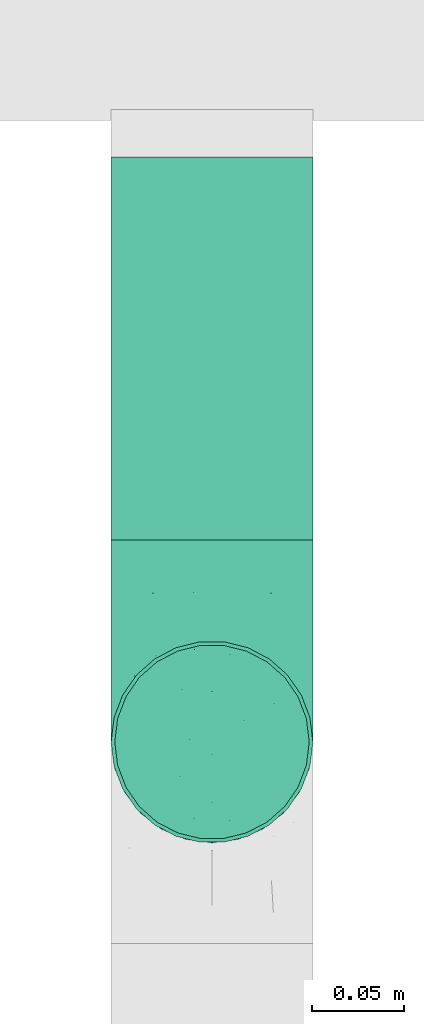
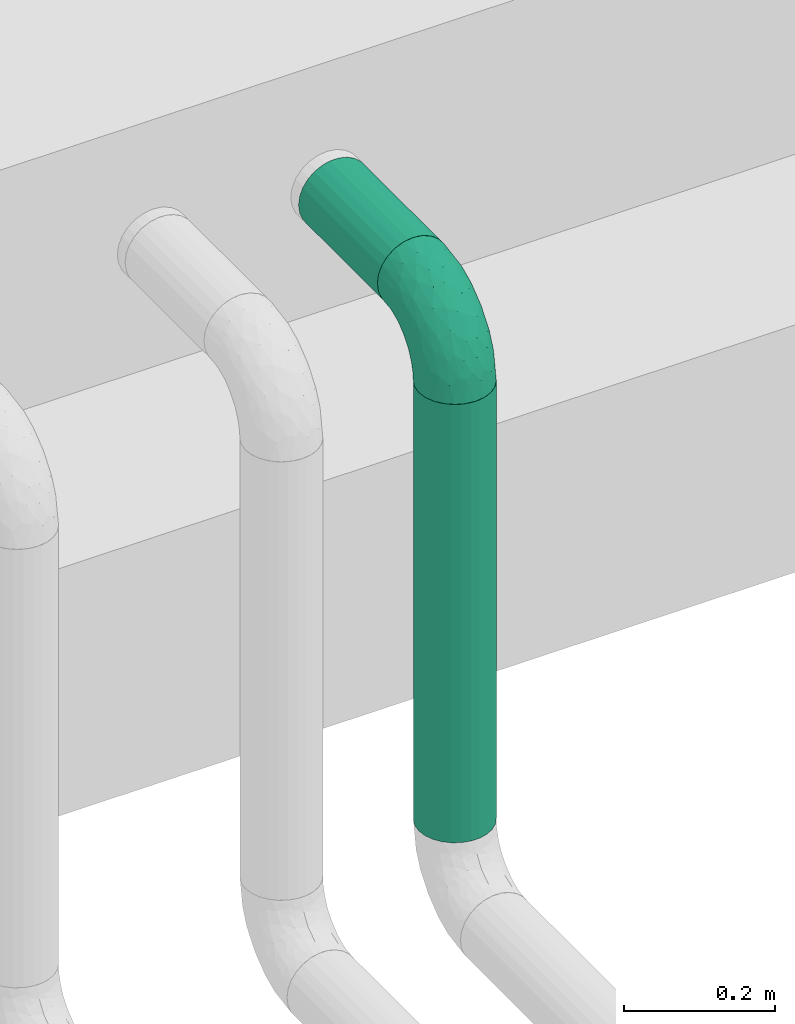
# One storey, part 25 of 91: 2 flow segments, 1 flow fitting.
"""IFC2X3 building model written with IfcOpenShell, lengths in millimetres."""

from ifc_helpers import new_model, entity, si_unit, converted_unit, derived_unit, direction, frame, origin_with_axes, origin_2d_with_axis, place, context, subcontext, project, spatial, hollow_circle, extrude, open_shell, surface_model, source, transform, mapped, material, layer, layer_set, layer_usage, type_object, element, save


model = new_model("IFC2X3")

# Units and contexts
model_context = context("Model", 3, precision=1e-05, world=origin_with_axes(), true_north=direction((0.0, 1.0)))
body_context = subcontext(model_context, "Body", "Model", "MODEL_VIEW")
ifc_project = project(units=[si_unit("AREAUNIT", "SQUARE_METRE"), si_unit("VOLUMEUNIT", "CUBIC_METRE", prefix="DECI"), si_unit("TIMEUNIT", "SECOND"), si_unit("THERMODYNAMICTEMPERATUREUNIT", "DEGREE_CELSIUS"), si_unit("PRESSUREUNIT", "PASCAL"), si_unit("MASSUNIT", "GRAM", prefix="KILO"), si_unit("LENGTHUNIT", "METRE", prefix="MILLI"), si_unit("POWERUNIT", "WATT"), si_unit("ELECTRICCURRENTUNIT", "AMPERE"), si_unit("ELECTRICVOLTAGEUNIT", "VOLT"), derived_unit("VOLUMETRICFLOWRATEUNIT", [(si_unit("VOLUMEUNIT", "CUBIC_METRE", prefix="DECI"), 1), (si_unit("TIMEUNIT", "SECOND"), -1)]), derived_unit("LINEARVELOCITYUNIT", [(si_unit("LENGTHUNIT", "METRE"), 1), (si_unit("TIMEUNIT", "SECOND"), -1)]), derived_unit("MASSDENSITYUNIT", [(si_unit("MASSUNIT", "GRAM", prefix="KILO"), 1), (si_unit("VOLUMEUNIT", "CUBIC_METRE"), -1)]), converted_unit("PLANEANGLEUNIT", "DEGREE", entity("IfcRatioMeasure", 0.01745), si_unit("PLANEANGLEUNIT", "RADIAN"), dimensions=[0, 0, 0, 0, 0, 0, 0])], contexts=[model_context])

# Site, building, storey
site_placement = place(None, origin_with_axes())
site = spatial("IfcSite", under=ifc_project, at=site_placement, CompositionType="ELEMENT")
building_placement = place(site_placement, origin_with_axes())
building = spatial("IfcBuilding", under=site, at=building_placement, Name="mc-building", CompositionType="ELEMENT")
storey_placement = place(building_placement, frame((0.0, 0.0, 8700.0), z_axis=(0.0, 0.0, 1.0), x_axis=(1.0, 0.0, 0.0)))
storey = spatial("IfcBuildingStorey", under=building, at=storey_placement, CompositionType="ELEMENT", Elevation=8700.0)

# Flow segments
ifc_material = material(Name="FZ1")
ifc_layer = layer(ifc_material, 0.0)
ifc_layer_set = layer_set([ifc_layer], Name="FZ1")
ifc_layer_usage = layer_usage(ifc_layer_set, "AXIS1", "POSITIVE", 0.0)
duct_segment_type = type_object("IfcDuctSegmentType", PredefinedType="RIGIDSEGMENT")
shared_shape_1 = source(origin_with_axes(), body_context, "Body", "SweptSolid", [
    extrude(hollow_circle(Radius=55.0, WallThickness=2.0, at=origin_2d_with_axis()), frame((0.0, 0.0, 0.0), z_axis=(1.0, 0.0, 0.0), x_axis=(0.0, 1.0, 0.0)), (0.0, 0.0, 1.0), 709.0),
])
flow_segment_1_placement = place(storey_placement, frame((16466.11947, 2612.35324, 1234.0), z_axis=(0.0, 1.0, 0.0), x_axis=(0.0, 0.0, -1.0)))
element("IfcFlowSegment", 1, at=flow_segment_1_placement, inside=storey, type_object=duct_segment_type, material=ifc_layer_usage, context=body_context, shape_type="MappedRepresentation", body=[
    mapped(shared_shape_1, transform((0.0, 0.0, 0.0), scale=1.0)),
])
shared_shape_2 = source(origin_with_axes(), body_context, "Body", "SweptSolid", [
    extrude(hollow_circle(Radius=55.0, WallThickness=2.0, at=origin_2d_with_axis()), frame((0.0, 0.0, 0.0), z_axis=(1.0, 0.0, 0.0), x_axis=(0.0, 1.0, 0.0)), (0.0, 0.0, 1.0), 208.9),
])
flow_segment_2_placement = place(storey_placement, frame((16466.11947, 2931.20513, 1344.0), z_axis=(0.0, 0.0, 1.0), x_axis=(0.0, -1.0, 0.0)))
element("IfcFlowSegment", 2, at=flow_segment_2_placement, inside=storey, type_object=duct_segment_type, material=ifc_layer_usage, context=body_context, shape_type="MappedRepresentation", body=[
    mapped(shared_shape_2, transform((0.0, 0.0, 0.0), scale=1.0, scale2=1.0, scale3=1.0, uniform=False)),
])

# Flow fitting
duct_fitting_type = type_object("IfcDuctFittingType", Name="BU", PredefinedType="BEND")
shared_shape_3 = source(origin_with_axes(), body_context, "Body", "SurfaceModel", [
    surface_model("IfcShellBasedSurfaceModel", [(-110.0, 0.0, -55.0), (-110.0, -14.23505, -53.12592), (-110.0, 14.23505, -53.12592), (-110.0, 53.12592, 14.23505), (-110.0, 27.5, -47.63139), (-110.0, 38.89087, -38.89087), (-110.0, -55.0, 0.0), (-110.0, -53.12592, 14.23505), (-110.0, -38.89087, -38.89087), (-110.0, -27.5, -47.63139), (-110.0, -53.12592, -14.23505), (-110.0, -47.63139, -27.5), (-110.0, -14.23505, 53.12592), (-110.0, 14.23505, 53.12592), (-110.0, 27.5, 47.63139), (-110.0, -47.63139, 27.5), (-110.0, -38.89087, 38.89087), (-110.0, -27.5, 47.63139), (-110.0, 0.0, 55.0), (-110.0, 55.0, 0.0), (-110.0, 53.12592, -14.23505), (-110.0, 47.63139, -27.5), (-110.0, 47.63139, 27.5), (-110.0, 38.89087, 38.89087), (-14.23505, 110.0, -53.12592), (-55.0, 110.0, 0.0), (0.0, 110.0, -55.0), (-27.5, 110.0, -47.63139), (-38.89087, 110.0, -38.89087), (-47.63139, 110.0, -27.5), (38.89087, 110.0, -38.89087), (53.12592, 110.0, 14.23505), (27.5, 110.0, -47.63139), (14.23505, 110.0, -53.12592), (47.63139, 110.0, -27.5), (53.12592, 110.0, -14.23505), (55.0, 110.0, 0.0), (-53.12592, 110.0, -14.23505), (-53.12592, 110.0, 14.23505), (-47.63139, 110.0, 27.5), (-38.89087, 110.0, 38.89087), (-27.5, 110.0, 47.63139), (0.0, 110.0, 55.0), (-14.23505, 110.0, 53.12592), (38.89087, 110.0, 38.89087), (47.63139, 110.0, 27.5), (27.5, 110.0, 47.63139), (14.23505, 110.0, 53.12592), (-64.21732, 48.68956, 43.63444), (-76.6405, 38.18013, 45.55988), (-60.44912, 32.56953, 51.94617), (-76.00813, 5.38378, 55.0), (-90.15553, 11.94394, 54.09138), (-78.5998, 26.77405, 50.81338), (-70.18771, 18.55163, 54.03432), (-75.55424, 54.2118, 32.41257), (-93.27622, 45.77614, 33.48188), (-96.12334, 22.13664, 50.81337), (-21.00813, 45.34362, 55.0), (-18.36258, 70.48427, 54.04484), (-32.04182, 59.64019, 52.24446), (-63.88653, 74.77858, 17.99134), (-74.66383, 63.08407, 19.92123), (-63.60674, 66.07878, 29.97482), (-99.597, 52.72185, 18.52927), (-93.11138, 56.59448, 10.50359), (-98.21577, 57.34403, 0.0), (-53.42855, 92.60092, 21.04759), (-88.54852, 54.8376, 21.04759), (-11.86161, 90.23965, 54.10313), (-5.38378, 76.00813, 55.0), (-57.34403, 98.21577, 0.0), (-56.64619, 93.12774, 10.22088), (-45.34362, 21.00813, 55.0), (-44.60838, 44.60838, 52.13415), (-92.68484, 35.46673, 43.63443), (-22.25266, 95.40765, 50.81337), (-35.97783, 90.61597, 43.63443), (-43.70931, 69.58671, 44.47149), (-27.23711, 77.39884, 50.81337), (-57.2828, 79.3123, 24.9774), (-58.67786, 84.31125, 16.04456), (-82.93277, 60.36161, 12.91784), (-49.88337, 54.51816, 47.224), (-74.57753, 66.83759, 9.55742), (-45.35812, 94.97281, 33.48188), (-59.18663, 88.95241, 0.0), (-51.517, 78.6292, 33.48188), (-65.14788, 80.03077, 0.0), (-56.45322, 62.06476, 39.63545), (-88.95241, 59.18663, 0.0), (-71.10913, 71.10913, 0.0), (-80.03077, 65.14788, 0.0), (-94.9309, 45.36788, -33.48188), (-93.11358, 56.60141, -10.46614), (-99.64997, 52.79499, -18.30015), (-90.20425, 36.08686, -43.63443), (-79.99933, 46.56772, -37.92748), (-76.00813, 5.38378, -55.0), (-72.75364, 19.68651, -53.60527), (-45.34362, 21.00813, -55.0), (-21.91957, 65.12078, -53.85897), (-5.38378, 76.00813, -55.0), (-21.00813, 45.34362, -55.0), (-35.41876, 92.89265, -43.63443), (-91.10309, 11.02766, -54.21832), (-45.77614, 93.27622, -33.48188), (-90.50474, 23.21022, -50.81337), (-70.92854, 33.31794, -49.51754), (-78.52933, 63.35627, -11.73997), (-24.91508, 84.05606, -50.81337), (-88.78941, 54.74452, -21.04759), (-69.59921, 57.34866, -33.48187), (-73.36422, 62.46673, -22.94182), (-63.49062, 67.59111, -28.46929), (-56.59448, 93.11138, -10.50359), (-54.8376, 88.54852, -21.04759), (-54.10679, 75.85581, -32.31867), (-57.75956, 31.09612, -52.80882), (-52.72185, 99.597, -18.52927), (-12.62913, 89.46304, -53.99097), (-34.46825, 66.46123, -50.04329), (-43.9837, 43.9837, -52.42279), (-65.78527, 72.58348, -17.68796), (-70.34468, 43.65295, -44.21951), (-57.47001, 51.99467, -44.91465), (-60.72547, 82.29174, -12.88567), (-42.34915, 74.24548, -43.63444), (-57.25194, 63.5016, -38.08211), (-80.95344, 53.56991, -29.32027), (-52.32891, 4.55257, -54.0482), (32.52942, 47.13398, -30.48571), (14.88266, 20.92917, -33.7947), (14.95561, 36.05775, -42.26543), (30.24048, 70.09027, -41.7461), (19.3559, 65.35825, -48.00507), (-70.35075, -46.44478, -19.5952), (-47.13398, -32.52942, -30.48571), (-28.49299, -30.5778, -16.4009), (-4.55257, 52.32891, -54.0482), (-22.4954, 22.4954, -53.25347), (-75.47368, -11.22546, -52.60718), (-81.32209, -51.5606, -9.98467), (-80.81763, -41.84862, -32.14655), (-70.09027, -30.24048, -41.7461), (-36.05774, -14.95561, -42.26543), (-9.15831, -10.852, -27.8997), (-65.35825, -19.3559, -48.00507), (11.22546, 75.47368, -52.60718), (3.94376, 43.9333, -50.53315), (-13.39742, 13.39743, -48.13058), (-43.9333, -3.94376, -50.53315), (49.37776, 67.29486, 0.0), (41.8609, 47.82256, -9.92641), (50.20582, 74.51695, -9.9731), (18.93131, 11.7156, -17.56239), (-27.5, -32.89419, 0.0), (-1.23348, -12.25375, -12.18106), (41.84862, 80.81763, -32.14655), (35.70604, 41.31408, -20.38235), (46.44478, 70.35075, -19.5952), (32.89419, 27.5, 0.0), (6.67262, -6.67262, 0.0), (-67.29486, -49.37776, 0.0), (-50.36265, -42.95545, -9.51562), (-5.47251, 5.47251, -39.92906), (-70.35075, -46.44478, 19.5952), (-74.51695, -50.20582, 9.9731), (-41.31407, -35.70604, 20.38235), (-47.13398, -32.52942, 30.48571), (-80.81763, -41.84862, 32.14655), (-4.55257, 52.32891, 54.0482), (11.22546, 75.47368, 52.60718), (-43.9333, -3.94376, 50.53315), (-65.35825, -19.3559, 48.00507), (-36.05774, -14.95561, 42.26543), (-70.09027, -30.24048, 41.7461), (-11.7156, -18.93131, 17.56239), (30.5778, 28.49299, 16.4009), (12.25375, 1.23348, 12.18106), (51.5606, 81.32209, 9.98467), (42.95545, 50.36265, 9.51562), (-75.47368, -11.22546, 52.60718), (-52.32891, 4.55257, 54.0482), (3.94376, 43.9333, 50.53315), (-22.4954, 22.4954, 53.25347), (-13.39742, 13.39743, 48.13058), (10.852, 9.15831, 27.8997), (-20.92916, -14.88266, 33.79469), (-47.82256, -41.8609, 9.92641), (32.52942, 47.13398, 30.48571), (46.44478, 70.35075, 19.5952), (41.84862, 80.81763, 32.14655), (30.24048, 70.09027, 41.7461), (19.3559, 65.35825, 48.00507), (14.95561, 36.05775, 42.26543), (-5.47251, 5.47251, 39.92906)], [open_shell([[[0, 1, 2]], [[2, 3, 4]], [[4, 3, 5]], [[2, 6, 7]], [[8, 6, 9]], [[1, 9, 6]], [[10, 6, 11]], [[8, 11, 6]], [[6, 2, 1]], [[12, 13, 14]], [[15, 2, 7]], [[16, 17, 2]], [[2, 17, 12]], [[12, 18, 13]], [[19, 20, 3]], [[5, 3, 21]], [[20, 21, 3]], [[22, 3, 2]], [[23, 22, 2]], [[12, 14, 2]], [[2, 14, 23]], [[15, 16, 2]], [[24, 25, 26]], [[27, 25, 24]], [[25, 28, 29]], [[28, 25, 27]], [[30, 26, 31]], [[26, 30, 32]], [[32, 33, 26]], [[34, 31, 35]], [[31, 34, 30]], [[35, 31, 36]], [[29, 37, 25]], [[38, 39, 26]], [[39, 40, 26]], [[41, 42, 40]], [[42, 26, 40]], [[42, 41, 43]], [[26, 44, 45]], [[31, 26, 45]], [[26, 46, 44]], [[47, 46, 26]], [[42, 47, 26]], [[25, 38, 26]], [[48, 49, 50]], [[18, 51, 52]], [[53, 54, 50]], [[55, 56, 49]], [[56, 22, 23]], [[13, 57, 14]], [[58, 59, 60]], [[61, 62, 63]], [[3, 64, 65]], [[53, 52, 54]], [[3, 65, 66]], [[67, 39, 38]], [[56, 68, 64]], [[65, 64, 68]], [[69, 59, 70]], [[38, 71, 72]], [[73, 58, 74]], [[75, 49, 56]], [[76, 69, 43]], [[53, 57, 52]], [[77, 78, 79]], [[41, 76, 43]], [[43, 69, 42]], [[55, 68, 56]], [[23, 14, 75]], [[76, 77, 79]], [[80, 67, 81]], [[62, 82, 68]], [[60, 78, 83]], [[62, 84, 82]], [[85, 77, 40]], [[81, 67, 72]], [[86, 72, 71]], [[87, 85, 67]], [[61, 81, 88]], [[77, 41, 40]], [[78, 77, 87]], [[23, 75, 56]], [[83, 89, 48]], [[85, 40, 39]], [[62, 68, 55]], [[89, 87, 63]], [[83, 48, 50]], [[57, 75, 14]], [[49, 75, 53]], [[67, 85, 39]], [[87, 77, 85]], [[63, 62, 55]], [[89, 55, 48]], [[80, 63, 87]], [[66, 65, 90]], [[66, 19, 3]], [[84, 91, 92]], [[92, 90, 82]], [[65, 82, 90]], [[61, 84, 62]], [[92, 82, 84]], [[68, 82, 65]], [[3, 22, 64]], [[56, 64, 22]], [[38, 25, 71]], [[81, 72, 86]], [[38, 72, 67]], [[91, 61, 88]], [[80, 81, 61]], [[63, 80, 61]], [[67, 80, 87]], [[77, 76, 41]], [[79, 59, 69]], [[79, 69, 76]], [[42, 69, 70]], [[60, 59, 79]], [[58, 70, 59]], [[78, 60, 79]], [[58, 60, 74]], [[52, 57, 13]], [[75, 57, 53]], [[18, 52, 13]], [[52, 51, 54]], [[51, 73, 54]], [[50, 73, 74]], [[73, 50, 54]], [[50, 74, 83]], [[60, 83, 74]], [[89, 83, 78]], [[87, 89, 78]], [[55, 89, 63]], [[50, 49, 53]], [[55, 49, 48]], [[81, 86, 88]], [[91, 84, 61]], [[5, 21, 93]], [[90, 94, 66]], [[20, 94, 95]], [[96, 93, 97]], [[98, 99, 100]], [[96, 4, 5]], [[101, 102, 103]], [[28, 27, 104]], [[2, 105, 0]], [[104, 106, 28]], [[99, 105, 107]], [[108, 107, 96]], [[90, 109, 94]], [[107, 2, 4]], [[20, 66, 94]], [[27, 24, 110]], [[109, 111, 94]], [[112, 113, 114]], [[37, 115, 71]], [[116, 106, 117]], [[99, 118, 100]], [[116, 115, 119]], [[37, 119, 115]], [[24, 120, 110]], [[121, 110, 101]], [[119, 106, 116]], [[101, 110, 120]], [[122, 103, 100]], [[117, 123, 116]], [[124, 125, 108]], [[115, 116, 126]], [[106, 29, 28]], [[26, 102, 120]], [[127, 104, 110]], [[97, 124, 96]], [[125, 122, 118]], [[128, 127, 125]], [[96, 5, 93]], [[115, 126, 86]], [[117, 106, 127]], [[111, 113, 129]], [[95, 93, 21]], [[97, 129, 112]], [[110, 104, 27]], [[106, 104, 127]], [[96, 107, 4]], [[99, 107, 108]], [[99, 108, 118]], [[105, 99, 98]], [[112, 114, 128]], [[121, 125, 127]], [[20, 19, 66]], [[109, 90, 92]], [[94, 111, 95]], [[91, 123, 109]], [[129, 113, 112]], [[93, 95, 111]], [[21, 20, 95]], [[71, 115, 86]], [[71, 25, 37]], [[123, 91, 88]], [[126, 116, 123]], [[123, 88, 126]], [[86, 126, 88]], [[37, 29, 119]], [[106, 119, 29]], [[129, 93, 111]], [[124, 112, 125]], [[0, 105, 98]], [[107, 105, 2]], [[125, 118, 108]], [[100, 118, 122]], [[93, 129, 97]], [[113, 111, 109]], [[109, 123, 113]], [[114, 123, 117]], [[123, 114, 113]], [[128, 114, 117]], [[127, 128, 117]], [[112, 128, 125]], [[103, 122, 101]], [[110, 121, 127]], [[101, 122, 121]], [[125, 121, 122]], [[26, 120, 24]], [[101, 120, 102]], [[96, 124, 108]], [[92, 91, 109]], [[112, 124, 97]], [[100, 130, 98]], [[131, 132, 133]], [[32, 134, 135]], [[136, 137, 138]], [[139, 140, 103]], [[98, 141, 0]], [[142, 10, 136]], [[143, 144, 137]], [[6, 10, 142]], [[137, 145, 146]], [[144, 147, 145]], [[143, 136, 11]], [[11, 136, 10]], [[8, 143, 11]], [[148, 149, 139]], [[8, 9, 144]], [[9, 1, 147]], [[130, 141, 98]], [[103, 140, 100]], [[148, 135, 149]], [[150, 151, 140]], [[152, 153, 154]], [[130, 140, 151]], [[148, 26, 33]], [[147, 1, 141]], [[155, 146, 132]], [[156, 138, 157]], [[134, 30, 158]], [[150, 140, 149]], [[158, 30, 34]], [[30, 134, 32]], [[153, 159, 160]], [[131, 160, 159]], [[144, 145, 137]], [[36, 152, 154]], [[146, 138, 137]], [[155, 161, 162]], [[158, 160, 131]], [[133, 149, 135]], [[156, 163, 164]], [[163, 142, 164]], [[139, 103, 102]], [[153, 152, 161]], [[34, 35, 160]], [[162, 157, 155]], [[132, 165, 133]], [[157, 146, 155]], [[140, 130, 100]], [[141, 130, 151]], [[141, 151, 147]], [[141, 1, 0]], [[102, 26, 148]], [[140, 139, 149]], [[102, 148, 139]], [[135, 33, 32]], [[151, 150, 145]], [[9, 147, 144]], [[151, 145, 147]], [[145, 165, 146]], [[135, 148, 33]], [[133, 135, 134]], [[131, 133, 134]], [[133, 165, 150]], [[133, 150, 149]], [[145, 150, 165]], [[132, 131, 159]], [[146, 165, 132]], [[160, 158, 34]], [[134, 158, 131]], [[144, 143, 8]], [[136, 143, 137]], [[155, 153, 161]], [[154, 153, 160]], [[153, 155, 159]], [[132, 159, 155]], [[160, 35, 154]], [[36, 154, 35]], [[164, 136, 138]], [[6, 142, 163]], [[136, 164, 142]], [[156, 164, 138]], [[156, 157, 162]], [[146, 157, 138]], [[15, 7, 166]], [[6, 163, 167]], [[168, 169, 166]], [[166, 169, 170]], [[171, 172, 70]], [[173, 174, 175]], [[17, 176, 174]], [[177, 156, 162]], [[176, 16, 170]], [[170, 16, 15]], [[161, 178, 179]], [[152, 180, 181]], [[182, 173, 183]], [[18, 12, 182]], [[184, 185, 186]], [[183, 185, 73]], [[183, 73, 51]], [[177, 187, 188]], [[189, 168, 166]], [[187, 178, 190]], [[16, 176, 17]], [[161, 152, 181]], [[45, 191, 31]], [[45, 44, 192]], [[192, 191, 45]], [[180, 36, 31]], [[193, 194, 195]], [[46, 47, 194]], [[193, 195, 190]], [[193, 44, 46]], [[172, 42, 70]], [[185, 58, 73]], [[189, 163, 156]], [[163, 189, 167]], [[70, 58, 171]], [[184, 171, 185]], [[169, 188, 175]], [[180, 31, 191]], [[192, 193, 190]], [[191, 190, 178]], [[182, 174, 173]], [[194, 47, 172]], [[190, 195, 187]], [[186, 185, 173]], [[162, 179, 177]], [[188, 196, 175]], [[179, 187, 177]], [[185, 171, 58]], [[172, 171, 184]], [[172, 184, 194]], [[172, 47, 42]], [[51, 18, 182]], [[185, 183, 173]], [[51, 182, 183]], [[174, 12, 17]], [[184, 186, 195]], [[46, 194, 193]], [[184, 195, 194]], [[195, 196, 187]], [[174, 182, 12]], [[175, 174, 176]], [[169, 175, 176]], [[175, 196, 186]], [[175, 186, 173]], [[195, 186, 196]], [[188, 169, 168]], [[187, 196, 188]], [[166, 170, 15]], [[176, 170, 169]], [[193, 192, 44]], [[191, 192, 190]], [[177, 189, 156]], [[167, 189, 166]], [[189, 177, 168]], [[188, 168, 177]], [[166, 7, 167]], [[6, 167, 7]], [[181, 191, 178]], [[36, 180, 152]], [[191, 181, 180]], [[161, 181, 178]], [[161, 179, 162]], [[187, 179, 178]]])]),
])
flow_fitting_placement = place(storey_placement, frame((16466.11947, 2612.35324, 1344.0), z_axis=(-1.0, 0.0, 0.0), x_axis=(0.0, 0.0, 1.0)))
element("IfcFlowFitting", 3, at=flow_fitting_placement, inside=storey, type_object=duct_fitting_type, Name="BU", context=body_context, shape_type="MappedRepresentation", body=[
    mapped(shared_shape_3, transform((0.0, 0.0, 0.0), scale=1.0)),
])

save(model, "model.ifc")
